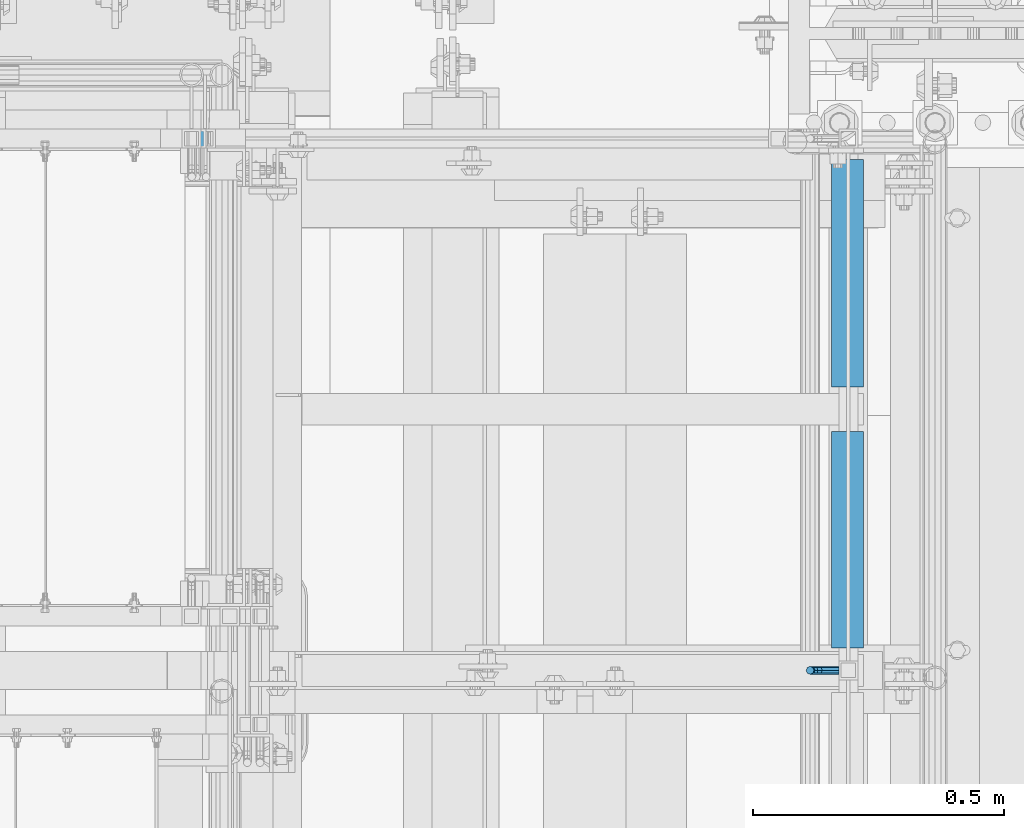
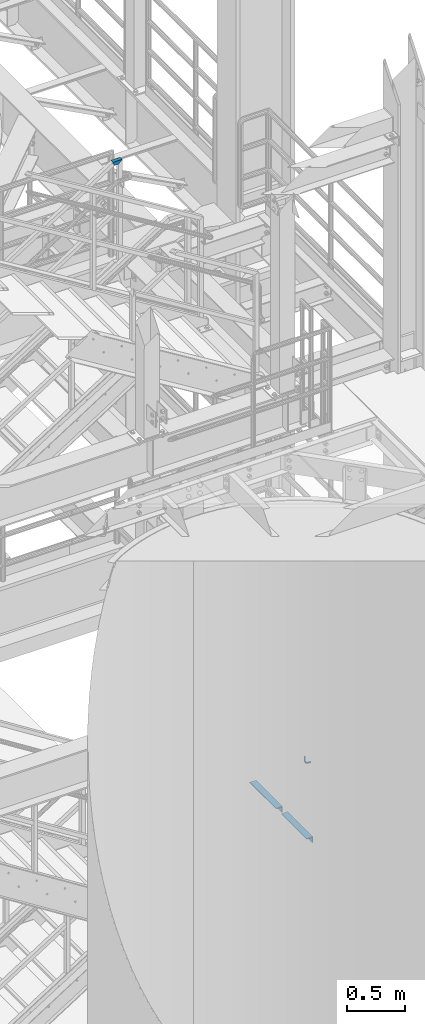
# One storey, part 1202 of 1876: 4 beams, 3 elements without a shape of their own.
"""IFC2X3 building model written with IfcOpenShell, lengths in millimetres."""

from ifc_helpers import new_model, si_unit, frame, origin_with_axes, place, context, subcontext, project, spatial, faceted_brep, material, type_object, element, aggregate, save


model = new_model("IFC2X3")

# Units and contexts
model_context = context("Model", 3, precision=1e-05, world=origin_with_axes())
body_context = subcontext(model_context, "Body", "Model", "MODEL_VIEW")
ifc_project = project(units=[si_unit("LENGTHUNIT", "METRE", prefix="MILLI"), si_unit("AREAUNIT", "SQUARE_METRE"), si_unit("VOLUMEUNIT", "CUBIC_METRE"), si_unit("MASSUNIT", "GRAM", prefix="KILO"), si_unit("TIMEUNIT", "SECOND"), si_unit("PLANEANGLEUNIT", "RADIAN"), si_unit("SOLIDANGLEUNIT", "STERADIAN"), si_unit("THERMODYNAMICTEMPERATUREUNIT", "DEGREE_CELSIUS"), si_unit("LUMINOUSINTENSITYUNIT", "LUMEN")], contexts=[model_context])

# Site, building, storey
site_placement = place(None, origin_with_axes())
site = spatial("IfcSite", under=ifc_project, at=site_placement, CompositionType="ELEMENT")
building_placement = place(site_placement, origin_with_axes())
building = spatial("IfcBuilding", under=site, at=building_placement, Name="Undefined", CompositionType="ELEMENT")
storey_placement = place(building_placement, origin_with_axes())
storey = spatial("IfcBuildingStorey", under=building, at=storey_placement, Name="Undefined", CompositionType="ELEMENT", Elevation=0.0)

# Assembly, beams
assembly_1_placement = place(storey_placement, origin_with_axes())
assembly_1 = element("IfcElementAssembly", 1, at=assembly_1_placement, inside=storey, Name="STRINGER", AssemblyPlace="NOTDEFINED", PredefinedType="RIGID_FRAME")
ifc_material_1 = material(Name="STEEL/A36")
beam_type_1 = type_object("IfcBeamType", Name="L2-1/2X2-1/2X1/4", PredefinedType="NOTDEFINED")
beam_1_placement = place(assembly_1_placement, frame((7445.37499944223, -5797.55000150562, 2266.27941824787), z_axis=(0.0, 0.0, -1.0), x_axis=(0.0, 1.0, 0.0)))
beam_1 = element("IfcBeam", 2, at=beam_1_placement, type_object=beam_type_1, material=ifc_material_1, Name="ANGLE", ObjectType="L2-1/2X2-1/2X1/4", context=body_context, shape_type="Brep", body=[
    faceted_brep([(0.0, 31.75, -31.75), (0.0, 31.75, 31.75), (431.800000762049, 31.75, 31.75), (431.800000762049, 31.75, -31.75), (0.0, 25.3999999999996, 31.75), (431.800000762049, 25.3999999999996, 31.75), (0.0, 25.3999999999996, -25.3999999999996), (431.800000762049, 25.3999999999996, -25.4000000000001), (0.0, -31.75, -25.3999999999996), (431.800000762049, -31.75, -25.4000000000001), (0.0, -31.75, -31.75), (431.800000762049, -31.75, -31.75)], [[[0, 1, 2, 3]], [[1, 4, 5, 2]], [[4, 6, 7, 5]], [[6, 8, 9, 7]], [[8, 10, 11, 9]], [[10, 0, 3, 11]], [[5, 7, 9, 11, 3, 2]], [[10, 8, 6, 4, 1, 0]]]),
])
beam_2_placement = place(assembly_1_placement, frame((7445.37499961838, -5276.8500013301, 2266.27941824264), z_axis=(0.0, 0.0, -1.0), x_axis=(0.0, 1.0, 0.0)))
beam_2 = element("IfcBeam", 3, at=beam_2_placement, type_object=beam_type_1, material=ifc_material_1, Name="ANGLE", ObjectType="L2-1/2X2-1/2X1/4", context=body_context, shape_type="Brep", body=[
    faceted_brep([(0.0, 31.75, -31.75), (0.0, 31.75, 31.75), (454.024500380441, 31.7499999997981, 31.75), (454.024500380441, 31.7499999997981, -31.75), (0.0, 25.3999999999996, 31.75), (454.024500380438, 25.3999999997977, 31.75), (0.0, 25.3999999999996, -25.3999999999996), (454.024500380438, 25.3999999997977, -25.4000000000001), (0.0, -31.75, -25.3999999999996), (454.024500380413, -31.7500000002019, -25.4000000000001), (0.0, -31.75, -31.75), (454.024500380413, -31.7500000002019, -31.75)], [[[0, 1, 2, 3]], [[1, 4, 5, 2]], [[4, 6, 7, 5]], [[6, 8, 9, 7]], [[8, 10, 11, 9]], [[10, 0, 3, 11]], [[5, 7, 9, 11, 3, 2]], [[10, 8, 6, 4, 1, 0]]]),
])
aggregate(assembly_1, [beam_1, beam_2])

# Assembly, beam
assembly_2_placement = place(storey_placement, origin_with_axes())
assembly_2 = element("IfcElementAssembly", 4, at=assembly_2_placement, inside=storey, Name="RAIL", AssemblyPlace="NOTDEFINED", PredefinedType="RIGID_FRAME")
ifc_material_2 = material()
beam_type_2 = type_object("IfcBeamType", Name="HSS1-1/2X1-1/2X1/8", PredefinedType="NOTDEFINED")
beam_3_placement = place(assembly_2_placement, frame((6081.03214427849, -4781.55000191054, 9220.19999873693), z_axis=(0.0, 0.0, -1.0), x_axis=(1.0, 0.0, 0.0)))
beam_3 = element("IfcBeam", 5, at=beam_3_placement, type_object=beam_type_2, material=ifc_material_2, Name="RAIL", ObjectType="HSS1-1/2X1-1/2X1/8", context=body_context, shape_type="Brep", body=[
    faceted_brep([(-4.62281069927667, 15.8749992829999, -15.8749992829999), (-4.62281069927667, -15.8749992829999, -15.8749992829999), (81.6428490494427, -15.8749992829999, -15.8749992829999), (81.6428490494427, 15.8749992829999, -15.8749992829999), (4.62281070567769, -15.8749992829999, 15.8749992829999), (49.892850483443, -15.8749992829999, 15.8749992829999), (4.62281070567769, 15.8749992829999, 15.8749992829999), (49.892850483443, 15.8749992829999, 15.8749992829999), (-5.54737286755244, 19.0499992349996, -19.0499992349996), (5.54737287395346, 19.0499992349996, 19.0499992349996), (46.7178505314432, 19.0499992349996, 19.0499992349996), (84.8178490014425, 19.0499992349996, -19.0499992349996), (5.54737287395346, -19.0499992349996, 19.0499992349996), (46.7178505314432, -19.0499992349996, 19.0499992349996), (-5.54737286755244, -19.0499992349996, -19.0499992349996), (84.8178490014425, -19.0499992349996, -19.0499992349996)], [[[0, 1, 2, 3]], [[1, 4, 5, 2]], [[4, 6, 7, 5]], [[6, 0, 3, 7]], [[8, 9, 10, 11]], [[9, 12, 13, 10]], [[12, 14, 15, 13]], [[14, 8, 11, 15]], [[13, 15, 11, 10], [5, 7, 3, 2]], [[14, 12, 9, 8], [6, 4, 1, 0]]]),
])
aggregate(assembly_2, [beam_3])

assembly_3_placement = place(storey_placement, origin_with_axes())
assembly_3 = element("IfcElementAssembly", 6, at=assembly_3_placement, inside=storey, Name="RAIL", AssemblyPlace="NOTDEFINED", PredefinedType="RIGID_FRAME")
beam_type_3 = type_object("IfcBeamType", PredefinedType="NOTDEFINED")
beam_4_placement = place(assembly_3_placement, frame((7427.912500765, -5842.00000037486, 3123.43417460616), z_axis=(0.0, 1.0, 0.0), x_axis=(-1.0, 0.0, 0.0)))
beam_4 = element("IfcBeam", 7, at=beam_4_placement, type_object=beam_type_3, material=ifc_material_1, Name="BRACKET", context=body_context, shape_type="Brep", body=[
    faceted_brep([(0.0, -7.9375, 0.0), (0.0, -5.61266007566822, -5.61266007566883), (23.8125, -5.61266007566883, -5.61266007566792), (23.8125, -7.9375, 0.0), (0.0, 0.0, -7.9375), (23.8125, 0.0, -7.9375), (0.0, 5.61266007566822, -5.61266007566883), (23.8125, 5.61266007566883, -5.61266007566792), (0.0, 7.9375, 0.0), (23.8125, 7.9375, 0.0), (0.0, 5.61266007566822, 5.61266007566883), (23.8125, 5.61266007566883, 5.61266007566792), (0.0, 0.0, 7.9375), (23.8125, 0.0, 7.9375), (0.0, -5.61266007566822, 5.61266007566883), (23.8125, -5.61266007566883, 5.61266007566792), (39.6077592547981, -4.79562758825341, 0.0), (38.7180815328556, -2.64775556579843, 5.61266007566792), (36.5702095103998, 2.53766620105671, 7.9375), (34.4223374879448, 7.72308796790821, 5.61266007566792), (33.5326597660023, 9.87095999036319, 0.0), (34.4223374879448, 7.72308796790821, -5.61266007566792), (36.5702095103998, 2.53766620105671, -7.9375), (38.7180815328556, -2.64775556579843, -5.61266007566792), (51.3544233967659, 5.79557812911298, -5.61266007566792), (52.9983334724348, 4.15166805344415, 0.0), (47.3856733967659, 9.76432812911298, -7.9375), (43.4169233967659, 13.733078129113, -5.61266007566792), (41.773013321098, 15.3769882047818, 0.0), (43.4169233967659, 13.733078129113, 5.61266007566792), (47.3856733967659, 9.76432812911298, 7.9375), (51.3544233967659, 5.79557812911298, 5.61266007566792), (59.7977570916764, 18.4319199930251, -5.61266007566792), (61.9456291141314, 17.5422422710835, 0.0), (54.6123353248231, 20.5797920154801, -7.9375), (49.4269135579698, 22.727664037935, -5.61266007566792), (47.2790415355148, 23.6173417598766, 0.0), (49.4269135579698, 22.727664037935, 5.61266007566792), (54.6123353248231, 20.5797920154801, 7.9375), (59.7977570916764, 18.4319199930251, 5.61266007566792), (62.7626616015468, 33.3375015258789, -5.61266007566792), (65.0875015258789, 33.3375015258789, 0.0), (57.1500015258789, 33.3375015258789, -7.9375), (51.5373414502101, 33.3375015258789, -5.61266007566792), (49.2125015258789, 33.3375015258789, 0.0), (51.5373414502101, 33.3375015258789, 5.61266007566792), (57.1500015258789, 33.3375015258789, 7.9375), (62.7626616015468, 33.3375015258789, 5.61266007566792), (62.7626616015468, 76.1999969482422, -5.61266007566792), (65.0875015258789, 76.1999969482422, 0.0), (57.1500015258789, 76.1999969482422, -7.9375), (51.537341450211, 76.1999969482422, -5.61266007566792), (49.2125015258789, 76.1999969482422, 0.0), (51.537341450211, 76.1999969482422, 5.61266007566792), (57.1500015258789, 76.1999969482422, 7.9375), (62.7626616015468, 76.1999969482422, 5.61266007566792)], [[[0, 1, 2, 3]], [[1, 4, 5, 2]], [[4, 6, 7, 5]], [[6, 8, 9, 7]], [[8, 10, 11, 9]], [[10, 12, 13, 11]], [[12, 14, 15, 13]], [[14, 0, 3, 15]], [[14, 12, 10, 8, 6, 4, 1, 0]], [[15, 3, 16, 17]], [[13, 15, 17, 18]], [[11, 13, 18, 19]], [[9, 11, 19, 20]], [[7, 9, 20, 21]], [[5, 7, 21, 22]], [[2, 5, 22, 23]], [[3, 2, 23, 16]], [[23, 24, 25, 16]], [[22, 26, 24, 23]], [[21, 27, 26, 22]], [[20, 28, 27, 21]], [[19, 29, 28, 20]], [[18, 30, 29, 19]], [[17, 31, 30, 18]], [[16, 25, 31, 17]], [[24, 32, 33, 25]], [[26, 34, 32, 24]], [[27, 35, 34, 26]], [[28, 36, 35, 27]], [[29, 37, 36, 28]], [[30, 38, 37, 29]], [[31, 39, 38, 30]], [[25, 33, 39, 31]], [[32, 40, 41, 33]], [[34, 42, 40, 32]], [[35, 43, 42, 34]], [[36, 44, 43, 35]], [[37, 45, 44, 36]], [[38, 46, 45, 37]], [[39, 47, 46, 38]], [[33, 41, 47, 39]], [[41, 40, 48, 49]], [[40, 42, 50, 48]], [[42, 43, 51, 50]], [[43, 44, 52, 51]], [[44, 45, 53, 52]], [[45, 46, 54, 53]], [[46, 47, 55, 54]], [[47, 41, 49, 55]], [[50, 51, 52, 53, 54, 55, 49, 48]]]),
])
aggregate(assembly_3, [beam_4])

save(model, "model.ifc")
